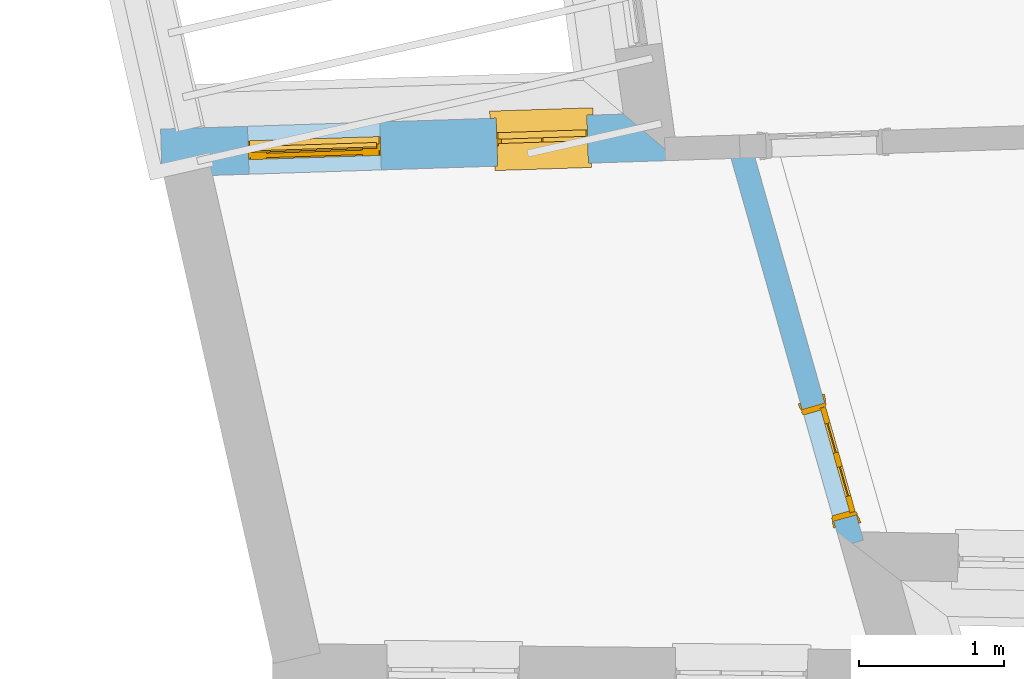
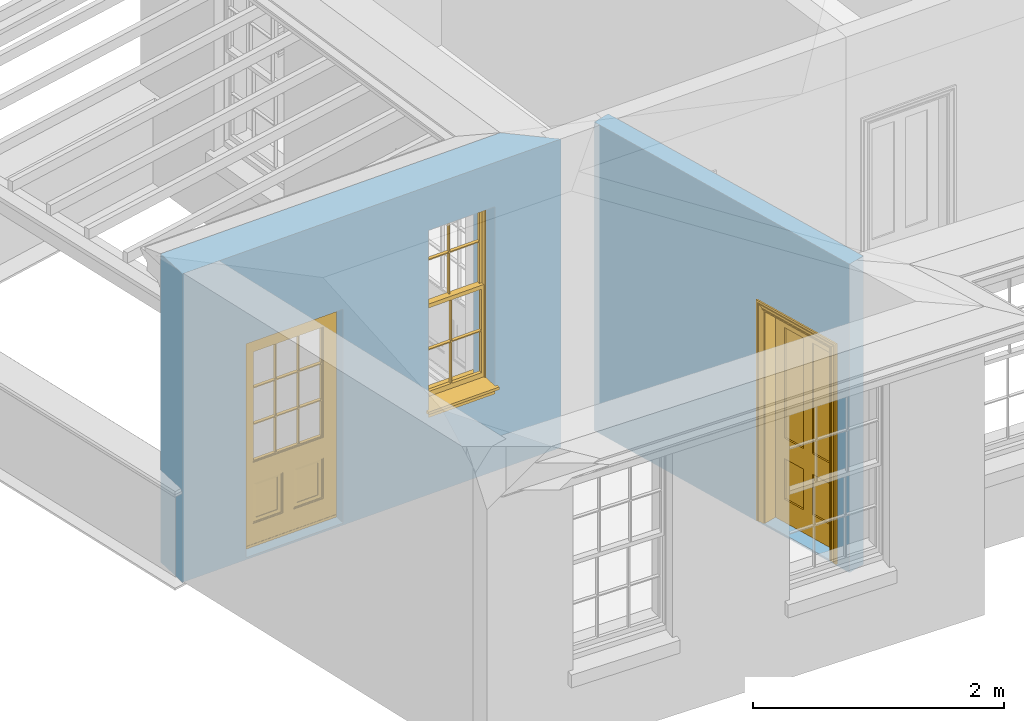
# One storey, part 3 of 11: 2 doors, 1 window, 3 openings, plus 2 elements that do not belong to this part.
"""IFC2X3 building model written with IfcOpenShell, lengths in metres."""

import ifcopenshell
import ifcopenshell.guid

model = None  # the IFC model being written
_history = None  # IfcOwnerHistory: only IFC2X3 demands one
_inside = {}  # id of a spatial element -> (the spatial element, [elements in it])
_under = {}  # id of a project, library or spatial element -> (it, [spatial elements below it])
_declared = {}  # id of a project -> (the project, [libraries it declares])
_typed = {}  # id of a type object -> (the type object, [elements of that type])
_made_of = {}  # id of a material, layer set ... -> (it, [elements and type objects made of it])


def new_model(schema):
    """Start an empty IFC model of exactly this schema.

    Asked for "IFC4X3", IfcOpenShell would pick the latest addendum, in which some entities
    have other attributes; the version numbers below select the first issue.
    IFC2X3 requires an IfcOwnerHistory on every rooted entity: one is made here for all.
    """
    global model, _history
    if schema == "IFC4X3":
        model = ifcopenshell.file(schema_version=(4, 3, 0, 0))
    else:
        model = ifcopenshell.file(schema=schema)
    _inside.clear()
    _under.clear()
    _declared.clear()
    _typed.clear()
    _made_of.clear()
    _history = None
    if model.schema == "IFC2X3":
        org = make("IfcOrganization", Name="unknown")
        user = make(
            "IfcPersonAndOrganization",
            ThePerson=make("IfcPerson", FamilyName="unknown"),
            TheOrganization=org,
        )
        app = make(
            "IfcApplication",
            ApplicationDeveloper=org,
            Version="unknown",
            ApplicationFullName="unknown",
            ApplicationIdentifier="unknown",
        )
        _history = make(
            "IfcOwnerHistory",
            OwningUser=user,
            OwningApplication=app,
            ChangeAction="ADDED",
            CreationDate=0,
        )
    return model


def make(cls, **values):
    """One entity of the class cls with the attributes given. An attribute that is None is left unset."""
    return model.create_entity(
        cls, **{name: value for name, value in values.items() if value is not None}
    )


def rooted(cls, **values):
    """An entity with a GlobalId (a new one), such as an element, a storey or a relation."""
    return make(cls, GlobalId=ifcopenshell.guid.new(), OwnerHistory=_history, **values)


def si_unit(unit_type, name, prefix=None):
    """IfcSIUnit, for example si_unit("LENGTHUNIT", "METRE", prefix="MILLI")."""
    return make("IfcSIUnit", UnitType=unit_type, Prefix=prefix, Name=name)


def assignment(units):
    """IfcUnitAssignment: the units of a project."""
    return None if units is None else make("IfcUnitAssignment", Units=units)


def point(xyz):
    """IfcCartesianPoint."""
    return None if xyz is None else make("IfcCartesianPoint", Coordinates=xyz)


def direction(xyz):
    """IfcDirection."""
    return None if xyz is None else make("IfcDirection", DirectionRatios=xyz)


def frame(location, z_axis=None, x_axis=None):
    """IfcAxis2Placement3D, a coordinate frame: its origin and axes. An axis left out is left unset."""
    return make(
        "IfcAxis2Placement3D",
        Location=point(location),
        Axis=direction(z_axis),
        RefDirection=direction(x_axis),
    )


def origin():
    """The frame at (0, 0, 0) with its axes left unset."""
    return frame((0.0, 0.0, 0.0))


def place(relative_to, where):
    """IfcLocalPlacement: puts the frame where relative to a parent placement (None: the world)."""
    return make(
        "IfcLocalPlacement", PlacementRelTo=relative_to, RelativePlacement=where
    )


def context(
    kind, dimensions, precision=None, world=None, true_north=None, identifier=None
):
    """IfcGeometricRepresentationContext, for example the 3D "Model" context."""
    return make(
        "IfcGeometricRepresentationContext",
        ContextIdentifier=identifier,
        ContextType=kind,
        CoordinateSpaceDimension=dimensions,
        Precision=precision,
        WorldCoordinateSystem=world,
        TrueNorth=true_north,
    )


def subcontext(parent, identifier, kind, view, scale=None):
    """IfcGeometricRepresentationSubContext, for example "Body" below "Model"."""
    return make(
        "IfcGeometricRepresentationSubContext",
        ContextIdentifier=identifier,
        ContextType=kind,
        ParentContext=parent,
        TargetScale=scale,
        TargetView=view,
    )


def project(units=None, contexts=None):
    """IfcProject with its units and contexts."""
    return rooted(
        "IfcProject",
        Name="project",
        RepresentationContexts=contexts,
        UnitsInContext=assignment(units),
    )


def spatial(cls, under=None, at=None, **own):
    """A site, building, storey or space (cls), placed at a placement, below another one or the project."""
    s = rooted(cls, ObjectPlacement=at, **own)
    if under is not None:
        _under.setdefault(under.id(), (under, []))[1].append(s)
    return s


def polyline(points):
    """IfcPolyline through the points."""
    return make("IfcPolyline", Points=[point(p) for p in points])


def outline(outer, holes=None, kind="AREA"):
    """IfcArbitraryClosedProfileDef: a profile drawn as a closed curve; with holes, ...WithVoids."""
    if holes is None:
        return make("IfcArbitraryClosedProfileDef", ProfileType=kind, OuterCurve=outer)
    return make(
        "IfcArbitraryProfileDefWithVoids",
        ProfileType=kind,
        OuterCurve=outer,
        InnerCurves=holes,
    )


def extrude(swept, where, along, depth):
    """IfcExtrudedAreaSolid: the profile swept, set in the frame where, extruded along a direction by depth."""
    return make(
        "IfcExtrudedAreaSolid",
        SweptArea=swept,
        Position=where,
        ExtrudedDirection=direction(along),
        Depth=depth,
    )


def faces_of(points, faces, orient=None, outer=None):
    """IfcFace entities. A face is a list of loops; a loop is a list of indices into points, from 0.

    orient and outer hold one flag for each loop. By default every Orientation is true, the
    first loop of a face is its IfcFaceOuterBound and the others are IfcFaceBound.
    """
    made = []
    for i, loops in enumerate(faces):
        bounds = []
        for j, loop in enumerate(loops):
            is_outer = j == 0 if outer is None else outer[i][j]
            bounds.append(
                make(
                    "IfcFaceOuterBound" if is_outer else "IfcFaceBound",
                    Bound=make("IfcPolyLoop", Polygon=[points[k] for k in loop]),
                    Orientation=True if orient is None else orient[i][j],
                )
            )
        made.append(make("IfcFace", Bounds=bounds))
    return made


def faceted_brep(points, faces, orient=None, outer=None, voids=None):
    """IfcFacetedBrep: a solid bounded by flat faces; with voids (closed shells), ...WithVoids."""
    shared = [point(p) for p in points]
    hull = make("IfcClosedShell", CfsFaces=faces_of(shared, faces, orient, outer))
    if voids is None:
        return make("IfcFacetedBrep", Outer=hull)
    return make(
        "IfcFacetedBrepWithVoids",
        Outer=hull,
        Voids=[
            make(cls, CfsFaces=faces_of(shared, fs, o, b)) for cls, fs, o, b in voids
        ],
    )


def shape(context_of_items, identifier, shape_type, items):
    """IfcShapeRepresentation: the items that make up one representation, for example the "Body"."""
    return make(
        "IfcShapeRepresentation",
        ContextOfItems=context_of_items,
        RepresentationIdentifier=identifier,
        RepresentationType=shape_type,
        Items=items,
    )


def material(Name=None, Category=None):
    """IfcMaterial."""
    return make("IfcMaterial", Name=Name, Category=Category)


def layer(
    of_material, thickness, ventilated=None, Name=None, Category=None, Priority=None
):
    """IfcMaterialLayer: one layer of a wall or slab, of a material (None: an air gap)."""
    return make(
        "IfcMaterialLayer",
        Material=of_material,
        LayerThickness=thickness,
        IsVentilated=ventilated,
        Name=Name,
        Category=Category,
        Priority=Priority,
    )


def layer_set(layers, Name=None):
    """IfcMaterialLayerSet."""
    return make("IfcMaterialLayerSet", MaterialLayers=layers, LayerSetName=Name)


def layer_usage(for_layer_set, set_direction, sense, offset, extent=None):
    """IfcMaterialLayerSetUsage: how a layer set lies in its element."""
    return make(
        "IfcMaterialLayerSetUsage",
        ForLayerSet=for_layer_set,
        LayerSetDirection=set_direction,
        DirectionSense=sense,
        OffsetFromReferenceLine=offset,
        ReferenceExtent=extent,
    )


def made_of(thing, what):
    """Note that an element or type object is made of a material, layer set ...; save() writes the relation."""
    if what is not None:
        _made_of.setdefault(what.id(), (what, []))[1].append(thing)
    return thing


def element(
    cls,
    number,
    at=None,
    inside=None,
    cuts=None,
    type_object=None,
    material=None,
    context=None,
    identifier="Body",
    shape_type=None,
    held_by="IfcProductDefinitionShape",
    body=None,
    shapes=None,
    **own,
):
    """One element of the class cls, such as IfcWall. Its Tag is "e" and its number.

    at: its placement. inside: the storey or other place that contains it. cuts: it is an
    opening in that element (IfcRelVoidsElement). A single representation is given by context,
    identifier, shape_type and body (its items); several are given by shapes. held_by: the class
    of the entity that holds the representations. save() writes the other relations.
    """
    e = rooted(cls, Tag="e%d" % number, ObjectPlacement=at, **own)
    if body is not None:
        shapes = [shape(context, identifier, shape_type, body)]
    if shapes is not None:
        e.Representation = make(held_by, Representations=shapes)
    if inside is not None:
        _inside.setdefault(inside.id(), (inside, []))[1].append(e)
    if cuts is not None:
        rooted(
            "IfcRelVoidsElement", RelatingBuildingElement=cuts, RelatedOpeningElement=e
        )
    if type_object is not None:
        _typed.setdefault(type_object.id(), (type_object, []))[1].append(e)
    return made_of(e, material)


def fill(opening, filler):
    """IfcRelFillsElement: the door or window that sits in an opening."""
    return rooted(
        "IfcRelFillsElement",
        RelatingOpeningElement=opening,
        RelatedBuildingElement=filler,
    )


def aggregate(whole, parts):
    """IfcRelAggregates: a whole, such as a stair, and the parts it consists of."""
    return rooted("IfcRelAggregates", RelatingObject=whole, RelatedObjects=parts)


def save(model, path):
    """Write the relations noted so far, then the file.

    IfcRelAggregates (storeys below a building ...), IfcRelContainedInSpatialStructure (elements
    in a storey), IfcRelDefinesByType, IfcRelAssociatesMaterial and IfcRelDeclares: one each for
    every whole, place, type object, material and project.
    """
    for whole, parts in _under.values():
        aggregate(whole, parts)
    for where, things in _inside.values():
        rooted(
            "IfcRelContainedInSpatialStructure",
            RelatedElements=things,
            RelatingStructure=where,
        )
    for kind, things in _typed.values():
        rooted("IfcRelDefinesByType", RelatedObjects=things, RelatingType=kind)
    for what, things in _made_of.values():
        rooted("IfcRelAssociatesMaterial", RelatedObjects=things, RelatingMaterial=what)
    for by, libraries in _declared.values():
        rooted("IfcRelDeclares", RelatingContext=by, RelatedDefinitions=libraries)
    model.write(path)


model = new_model("IFC2X3")

# Units and contexts
model_context = context("Model", 3, world=origin())
body_context = subcontext(model_context, "Body", "Model", "MODEL_VIEW")
ifc_project = project(units=[si_unit("PLANEANGLEUNIT", "RADIAN"), si_unit("MASSUNIT", "GRAM", prefix="KILO"), si_unit("FORCEUNIT", "NEWTON", prefix="KILO"), si_unit("LENGTHUNIT", "METRE")], contexts=[model_context])

# Site, building, storey
site_placement = place(None, origin())
site = spatial("IfcSite", under=ifc_project, at=site_placement, CompositionType="ELEMENT")
building_placement = place(None, origin())
building = spatial("IfcBuilding", under=site, at=building_placement, Name="Building plot-10", CompositionType="ELEMENT")
storey_placement = place(None, frame((0.0, 0.0, 4.6)))
storey = spatial("IfcBuildingStorey", under=building, at=storey_placement, Name="Floor 1", CompositionType="ELEMENT", Elevation=4.6)

# Wall, openings, window, door
ifc_material_1 = material(Name="Masonry")
ifc_layer_1 = layer(ifc_material_1, 0.33, ventilated=False)
ifc_layer_set_1 = layer_set([ifc_layer_1], Name="My Wall")
ifc_layer_usage_1 = layer_usage(ifc_layer_set_1, "AXIS2", "NEGATIVE", 0.08)
wall_1_placement = place(storey_placement, origin())
wall_1 = element("IfcWallStandardCase", 1, at=wall_1_placement, inside=storey, material=ifc_layer_usage_1, Name="exterior", context=body_context, shape_type="SweptSolid", body=[
    extrude(outline(polyline([(44.9907273404709, 19.9050530553829), (44.613794117192, 20.222948147817), (41.4317582674974, 20.1192816168719), (41.4425035313938, 19.7894566037152), (44.9907273404709, 19.9050530553829)])), origin(), (0.0, 0.0, 1.0), 3.0),
])
opening_1_placement = place(storey_placement, frame((0.0, 0.0, 0.75)))
opening_1 = element("IfcOpeningElement", 2, at=opening_1_placement, cuts=wall_1, Name="Opening", ObjectType="Opening", context=body_context, shape_type="SweptSolid", body=[
    extrude(outline(polyline([(44.3630246910205, 20.2147784106719), (43.7383561054965, 20.1944275320802), (43.7491013693929, 19.8646025189235), (44.3737699549169, 19.8849533975153), (44.3630246910205, 20.2147784106719)])), origin(), (0.0, 0.0, 1.0), 1.82),
])
opening_2_placement = place(storey_placement, frame((0.0, 0.0, 0.0199999999999996)))
opening_2 = element("IfcOpeningElement", 3, at=opening_2_placement, cuts=wall_1, Name="Opening", ObjectType="Opening", context=body_context, shape_type="SweptSolid", body=[
    extrude(outline(polyline([(42.9387803160258, 20.1683784074828), (42.0292628555029, 20.1387475282532), (42.0400081193993, 19.8089225150966), (42.9495255799222, 19.8385533943261), (42.9387803160258, 20.1683784074828)])), origin(), (0.0, 0.0, 1.0), 2.08),
])
window_placement = place(storey_placement, frame((44.3711650424572, 19.9649109764623, 0.75), z_axis=(0.0, 0.0, 1.0), x_axis=(-0.624668585523992, -0.0203508785917279, 0.0)))
window = element("IfcWindow", 4, at=window_placement, inside=storey, Name="bedroom outside window", OverallHeight=1.82, OverallWidth=0.625, context=body_context, shape_type="Brep", held_by="IfcProductRepresentation", body=[
    faceted_brep([(0.033125, -0.105, 0.975209), (0.01, -0.105, 0.975209), (0.033125, -0.105, 1.376042), (0.591875, -0.105, 0.975209), (0.591875, -0.105, 1.376042), (0.615, -0.105, 0.975209), (0.591875, -0.105, 1.386042), (0.591875, -0.105, 1.786875), (0.615, -0.105, 1.81), (0.033125, -0.105, 1.786875), (0.033125, -0.105, 1.386042), (0.01, -0.105, 1.81), (0.591875, -0.135, 1.376042), (0.591875, -0.135, 0.975209), (0.615, -0.135, 0.937083), (0.033125, -0.135, 1.786875), (0.01, -0.135, 1.81), (0.033125, -0.135, 1.386042), (0.01, -0.135, 0.937083), (0.033125, -0.135, 0.975209), (0.033125, -0.135, 1.376042), (0.591875, -0.135, 1.786875), (0.591875, -0.135, 1.386042), (0.615, -0.135, 1.81), (0.033125, -0.105, 0.937083), (0.01, -0.105, 0.937083), (0.033125, -0.105, 0.53625), (0.591875, -0.105, 0.937083), (0.591875, -0.105, 0.53625), (0.615, -0.105, 0.937083), (0.591875, -0.105, 0.52625), (0.591875, -0.105, 0.125417), (0.615, -0.105, 0.077167), (0.033125, -0.105, 0.125417), (0.033125, -0.105, 0.52625), (0.01, -0.105, 0.077167), (-0.0425, -0.25, 0.01), (-0.0425, -0.3, 0.001667), (0.0, -0.25, 0.01), (0.6675, -0.25, 0.01), (0.625, -0.25, 0.01), (0.6675, -0.3, 0.001667), (-0.02, 0.08, 0.077167), (0.0, 0.08, 0.077167), (-0.02, 0.11, 0.077167), (0.0, -0.06, 0.077167), (0.01, -0.06, 0.077167), (0.625, -0.06, 0.077167), (0.625, 0.08, 0.077167), (0.615, -0.06, 0.077167), (0.645, 0.08, 0.077167), (0.645, 0.11, 0.077167), (0.01, -0.075, 0.975209), (0.615, -0.075, 0.975209), (0.591875, -0.075, 0.125417), (0.591875, -0.075, 0.52625), (0.615, -0.075, 0.077167), (0.591875, -0.075, 0.53625), (0.591875, -0.075, 0.937083), (0.033125, -0.075, 0.125417), (0.01, -0.075, 0.077167), (0.033125, -0.075, 0.52625), (0.033125, -0.075, 0.937083), (0.033125, -0.075, 0.53625), (-0.02, 0.08, 0.052167), (-0.02, 0.11, 0.052167), (0.645, 0.11, 0.052167), (0.645, 0.08, 0.052167), (0.625, 0.08, 0.052167), (0.0, 0.08, 0.052167), (0.625, -0.15, 0.026667), (0.0, -0.15, 0.026667), (-0.0425, -0.3, -0.123333), (0.6675, -0.3, -0.123333), (-0.0425, -0.25, -0.123333), (0.6675, -0.25, -0.123333), (0.01, -0.06, 1.81), (0.615, -0.06, 1.81), (0.0, -0.06, 1.82), (0.625, -0.06, 1.82), (0.01, -0.15, 0.077167), (0.615, -0.15, 0.077167), (0.3175, -0.075, 0.53625), (0.3175, -0.105, 0.53625), (0.3175, -0.075, 0.52625), (0.3175, -0.075, 0.125417), (0.3075, -0.075, 0.125417), (0.3075, -0.075, 0.52625), (0.3075, -0.075, 0.53625), (0.3175, -0.075, 0.937083), (0.3075, -0.075, 0.937083), (0.3075, -0.105, 0.52625), (0.3075, -0.105, 0.125417), (0.3175, -0.105, 0.125417), (0.3175, -0.105, 0.52625), (0.3075, -0.105, 0.53625), (0.3075, -0.105, 0.937083), (0.3175, -0.105, 0.937083), (0.3075, -0.135, 1.386042), (0.3075, -0.135, 1.376042), (0.3175, -0.135, 1.376042), (0.3075, -0.135, 0.975209), (0.3175, -0.135, 0.975209), (0.3175, -0.135, 1.786875), (0.3075, -0.135, 1.786875), (0.3175, -0.135, 1.386042), (0.3175, -0.105, 1.386042), (0.3175, -0.105, 1.376042), (0.3075, -0.105, 1.386042), (0.3075, -0.105, 1.786875), (0.3175, -0.105, 1.786875), (0.3075, -0.105, 1.376042), (0.3175, -0.105, 0.975209), (0.3075, -0.105, 0.975209), (0.625, -0.15, 1.82), (0.615, -0.15, 1.81), (0.01, -0.15, 1.81), (0.0, -0.15, 1.82), (0.625, -0.25, 0.0), (0.0, -0.25, 0.0), (0.625, 0.08, 0.0), (0.0, 0.08, 0.0)], [[[0, 1, 2]], [[3, 4, 5]], [[6, 7, 8]], [[9, 10, 11]], [[12, 13, 14]], [[15, 16, 17]], [[18, 19, 20]], [[21, 22, 23]], [[24, 25, 26]], [[27, 28, 29]], [[30, 31, 32]], [[33, 34, 35]], [[14, 27, 29]], [[25, 24, 18]], [[36, 37, 38]], [[39, 40, 41]], [[42, 43, 44]], [[45, 46, 43]], [[47, 48, 49]], [[50, 51, 48]], [[1, 0, 52]], [[5, 53, 3]], [[54, 55, 56]], [[57, 58, 53]], [[59, 60, 61]], [[62, 63, 52]], [[48, 43, 46, 49]], [[51, 44, 43, 48]], [[64, 42, 44, 65]], [[65, 44, 51, 66]], [[66, 51, 50, 67]], [[65, 66, 68, 69]], [[60, 56, 49, 46]], [[70, 71, 38, 40]], [[37, 41, 40, 38]], [[37, 72, 73, 41]], [[74, 75, 73, 72]], [[8, 11, 76, 77]], [[76, 78, 79, 77]], [[32, 35, 80, 81]], [[81, 80, 71, 70]], [[28, 57, 82, 83]], [[84, 85, 86, 87]], [[88, 87, 61, 63]], [[89, 82, 88, 90]], [[84, 82, 57, 55]], [[91, 87, 86, 92]], [[34, 61, 87, 91]], [[93, 85, 84, 94]], [[95, 88, 63, 26]], [[96, 90, 88, 95]], [[83, 82, 89, 97]], [[94, 84, 55, 30]], [[94, 30, 28, 83]], [[94, 91, 92, 93]], [[95, 26, 34, 91]], [[97, 96, 95, 83]], [[98, 17, 20, 99]], [[100, 99, 101, 102]], [[103, 104, 98, 105]], [[100, 12, 22, 105]], [[106, 6, 4, 107]], [[106, 108, 109, 110]], [[111, 2, 10, 108]], [[112, 113, 111, 107]], [[99, 111, 113, 101]], [[20, 2, 111, 99]], [[102, 112, 107, 100]], [[98, 108, 10, 17]], [[104, 109, 108, 98]], [[105, 106, 110, 103]], [[22, 6, 106, 105]], [[100, 107, 4, 12]], [[82, 84, 87, 88]], [[83, 95, 91, 94]], [[99, 100, 105, 98]], [[107, 111, 108, 106]], [[92, 86, 59, 33]], [[15, 9, 109, 104]], [[103, 110, 7, 21]], [[31, 54, 85, 93]], [[36, 74, 72, 37]], [[39, 41, 73, 75]], [[18, 14, 102, 101]], [[23, 16, 104, 103]], [[85, 56, 60, 86]], [[52, 53, 89, 90]], [[53, 52, 113, 112]], [[11, 8, 110, 109]], [[14, 18, 96, 97]], [[2, 1, 11, 10]], [[8, 5, 4, 6]], [[57, 53, 56, 55]], [[60, 52, 63, 61]], [[26, 25, 35, 34]], [[32, 29, 28, 30]], [[14, 23, 22, 12]], [[18, 20, 17, 16]], [[19, 0, 2, 20]], [[17, 10, 9, 15]], [[12, 4, 3, 13]], [[21, 7, 6, 22]], [[27, 58, 57, 28]], [[30, 55, 54, 31]], [[33, 59, 61, 34]], [[26, 63, 62, 24]], [[5, 8, 77, 53]], [[76, 11, 1, 52]], [[46, 45, 78, 76]], [[49, 77, 79, 47]], [[70, 114, 115, 81]], [[71, 80, 116, 117]], [[19, 101, 113, 0]], [[102, 13, 3, 112]], [[90, 96, 24, 62]], [[29, 32, 81, 14]], [[80, 35, 25, 18]], [[60, 46, 76, 52]], [[77, 49, 56, 53]], [[23, 14, 81, 115]], [[16, 116, 80, 18]], [[92, 33, 35]], [[32, 31, 93]], [[32, 93, 92, 35]], [[14, 13, 102]], [[101, 19, 18]], [[103, 21, 23]], [[16, 15, 104]], [[109, 9, 11]], [[8, 7, 110]], [[23, 115, 116, 16]], [[114, 117, 116, 115]], [[90, 62, 52]], [[58, 89, 53]], [[27, 97, 89, 58]], [[85, 54, 56]], [[60, 59, 86]], [[97, 27, 14]], [[18, 24, 96]], [[52, 0, 113]], [[112, 3, 53]], [[79, 78, 117, 114]], [[78, 45, 71, 117]], [[114, 70, 47, 79]], [[118, 75, 74, 119]], [[68, 66, 67]], [[48, 68, 67, 50]], [[69, 64, 65]], [[42, 64, 69, 43]], [[69, 68, 120, 121]], [[70, 68, 48, 47]], [[118, 120, 68, 70]], [[43, 69, 71, 45]], [[69, 121, 119, 71]], [[120, 118, 119, 121]], [[38, 119, 74, 36]], [[71, 119, 38]], [[39, 75, 118, 40]], [[40, 118, 70]]]),
])
fill(opening_1, window)
door_1_placement = place(storey_placement, frame((42.9469206674625, 19.9185109732732, 0.0199999999999996), z_axis=(0.0, 0.0, 1.0), x_axis=(-0.909517460522935, -0.0296308792295576, 0.0)))
door_1 = element("IfcDoor", 5, at=door_1_placement, inside=storey, Name="bedroom outside door", OverallHeight=2.08, OverallWidth=0.91, context=body_context, shape_type="Brep", held_by="IfcProductRepresentation", body=[
    faceted_brep([(0.545, -0.055, 0.265), (0.745, -0.055, 0.265), (0.745, -0.05, 0.265), (0.545, -0.05, 0.265), (0.745, -0.05, 0.58), (0.545, -0.05, 0.58), (0.545, -0.055, 0.58), (0.515, -0.06, 0.235), (0.775, -0.06, 0.235), (0.745, -0.055, 0.58), (0.515, -0.06, 0.61), (0.515, -0.065, 0.235), (0.775, -0.065, 0.235), (0.775, -0.06, 0.61), (0.515, -0.065, 0.61), (0.785, -0.065, 0.225), (0.505, -0.065, 0.225), (0.775, -0.065, 0.61), (0.505, -0.065, 0.62), (0.785, -0.065, 0.62), (0.505, -0.07, 0.225), (0.785, -0.07, 0.225), (0.505, -0.07, 0.62), (0.785, -0.07, 0.62), (0.883, -0.07, 0.075), (0.898, -0.07, 0.075), (0.405, -0.07, 0.62), (0.405, -0.07, 0.225), (0.027, -0.07, 0.075), (0.785, -0.07, 0.82), (0.125, -0.07, 0.82), (0.405, -0.065, 0.62), (0.405, -0.065, 0.225), (0.898, -0.07, 2.068), (0.027, -0.08, 0.075), (0.883, -0.08, 0.075), (0.125, -0.07, 0.225), (0.012, -0.07, 0.075), (0.785, -0.06, 0.82), (0.125, -0.06, 0.82), (0.125, -0.07, 0.62), (0.125, -0.065, 0.62), (0.395, -0.065, 0.61), (0.395, -0.065, 0.235), (0.125, -0.065, 0.225), (0.785, -0.07, 1.895), (0.027, -0.11, 0.045), (0.883, -0.11, 0.045), (0.558333, -0.06, 0.83), (0.351667, -0.06, 0.83), (0.125, -0.07, 1.895), (0.125, -0.06, 1.895), (0.785, -0.06, 1.895), (0.012, -0.07, 2.068), (0.135, -0.065, 0.61), (0.395, -0.06, 0.61), (0.395, -0.06, 0.235), (0.135, -0.065, 0.235), (0.027, -0.11, 0.027), (0.883, -0.11, 0.027), (0.568333, -0.06, 0.83), (0.558333, -0.03, 0.83), (0.351667, -0.03, 0.83), (0.341667, -0.06, 0.83), (0.135, -0.06, 1.185), (0.135, -0.06, 1.53), (0.775, -0.06, 1.53), (0.775, -0.06, 1.185), (0.135, -0.06, 0.61), (0.365, -0.055, 0.58), (0.365, -0.055, 0.265), (0.135, -0.06, 0.235), (0.568333, -0.06, 1.175), (0.558333, -0.06, 1.175), (0.775, -0.06, 0.83), (0.558333, -0.03, 1.175), (0.785, -0.03, 0.82), (0.125, -0.03, 0.82), (0.351667, -0.03, 1.175), (0.351667, -0.06, 1.175), (0.341667, -0.06, 1.175), (0.135, -0.06, 0.83), (0.135, -0.06, 1.175), (0.135, -0.03, 1.185), (0.135, -0.03, 1.53), (0.135, -0.06, 1.54), (0.351667, -0.06, 1.885), (0.558333, -0.06, 1.885), (0.775, -0.03, 1.53), (0.775, -0.03, 1.185), (0.775, -0.06, 1.175), (0.775, -0.06, 1.54), (0.165, -0.055, 0.58), (0.365, -0.05, 0.58), (0.365, -0.05, 0.265), (0.165, -0.055, 0.265), (0.568333, -0.03, 0.83), (0.568333, -0.03, 1.175), (0.568333, -0.06, 1.185), (0.558333, -0.06, 1.185), (0.775, -0.03, 0.83), (0.785, -0.02, 0.82), (0.125, -0.02, 0.82), (0.341667, -0.03, 0.83), (0.341667, -0.03, 1.175), (0.351667, -0.06, 1.185), (0.341667, -0.06, 1.185), (0.135, -0.03, 0.83), (0.341667, -0.03, 1.185), (0.125, -0.03, 1.895), (0.341667, -0.03, 1.53), (0.341667, -0.06, 1.53), (0.135, -0.06, 1.885), (0.341667, -0.06, 1.54), (0.341667, -0.06, 1.885), (0.558333, -0.03, 1.885), (0.351667, -0.03, 1.885), (0.568333, -0.06, 1.885), (0.785, -0.03, 1.895), (0.568333, -0.03, 1.185), (0.568333, -0.06, 1.53), (0.568333, -0.03, 1.53), (0.568333, -0.06, 1.54), (0.775, -0.06, 1.885), (0.165, -0.05, 0.58), (0.165, -0.05, 0.265), (0.775, -0.03, 1.175), (0.558333, -0.06, 1.53), (0.351667, -0.03, 1.185), (0.558333, -0.03, 1.185), (0.505, -0.02, 0.62), (0.405, -0.02, 0.62), (0.125, -0.02, 1.895), (0.785, -0.02, 1.895), (0.351667, -0.06, 1.53), (0.135, -0.03, 1.175), (0.135, -0.03, 1.54), (0.341667, -0.03, 1.54), (0.135, -0.03, 1.885), (0.351667, -0.06, 1.54), (0.558333, -0.03, 1.54), (0.558333, -0.06, 1.54), (0.351667, -0.03, 1.54), (0.775, -0.03, 1.54), (0.568333, -0.03, 1.54), (0.775, -0.03, 1.885), (0.558333, -0.03, 1.53), (0.405, -0.02, 0.225), (0.505, -0.02, 0.225), (0.125, -0.02, 0.62), (0.785, -0.02, 0.62), (0.012, -0.02, 2.068), (0.898, -0.02, 2.068), (0.351667, -0.03, 1.53), (0.341667, -0.03, 1.885), (0.568333, -0.03, 1.885), (0.405, -0.025, 0.225), (0.405, -0.025, 0.62), (0.505, -0.025, 0.62), (0.505, -0.025, 0.225), (0.898, -0.02, 0.027), (0.012, -0.02, 0.027), (0.125, -0.025, 0.62), (0.785, -0.025, 0.62), (0.395, -0.025, 0.235), (0.395, -0.025, 0.61), (0.125, -0.02, 0.225), (0.125, -0.025, 0.225), (0.515, -0.025, 0.61), (0.515, -0.025, 0.235), (0.785, -0.02, 0.225), (0.785, -0.025, 0.225), (0.135, -0.025, 0.61), (0.775, -0.025, 0.61), (0.135, -0.025, 0.235), (0.395, -0.03, 0.235), (0.395, -0.03, 0.61), (0.515, -0.03, 0.61), (0.515, -0.03, 0.235), (0.775, -0.025, 0.235), (0.135, -0.03, 0.61), (0.775, -0.03, 0.61), (0.135, -0.03, 0.235), (0.365, -0.035, 0.265), (0.365, -0.035, 0.58), (0.545, -0.035, 0.58), (0.545, -0.035, 0.265), (0.775, -0.03, 0.235), (0.165, -0.035, 0.58), (0.745, -0.035, 0.58), (0.165, -0.035, 0.265), (0.365, -0.04, 0.58), (0.365, -0.04, 0.265), (0.545, -0.04, 0.58), (0.545, -0.04, 0.265), (0.745, -0.035, 0.265), (0.165, -0.04, 0.58), (0.745, -0.04, 0.58), (0.165, -0.04, 0.265), (0.745, -0.04, 0.265), (0.885, -0.072, 0.025), (0.025, -0.072, 0.025), (0.025, -0.1, 0.025), (0.885, -0.1, 0.025), (0.9, -0.02, 0.025), (0.01, -0.02, 0.025), (0.9, -0.072, 0.025), (0.91, -0.02, 0.0), (0.0, -0.02, 0.0), (0.01, -0.072, 0.025), (0.9, -0.072, 2.07), (0.9, -0.02, 2.07), (0.885, -0.072, 2.055), (0.91, -0.02, 2.08), (0.01, -0.02, 2.07), (0.0, -0.02, 2.08), (0.01, -0.072, 2.07), (0.025, -0.072, 2.055), (0.0, -0.15, 2.08), (0.91, -0.15, 2.08), (0.01, -0.15, 2.07), (0.9, -0.15, 2.07), (0.01, -0.1, 2.07), (0.9, -0.1, 2.07), (0.0, -0.15, 0.0), (0.91, -0.15, 0.0), (0.01, -0.15, 0.025), (0.9, -0.15, 0.025), (0.01, -0.1, 0.025), (0.025, -0.1, 2.055), (0.9, -0.1, 0.025), (0.885, -0.1, 2.055), (0.898, -0.07, 0.027), (0.012, -0.07, 0.027), (0.883, -0.07, 0.027), (0.027, -0.07, 0.027)], [[[0, 1, 2, 3]], [[2, 4, 5, 3]], [[0, 3, 5, 6]], [[1, 0, 7, 8]], [[9, 4, 2, 1]], [[9, 6, 5, 4]], [[0, 6, 10, 7]], [[8, 7, 11, 12]], [[8, 13, 9, 1]], [[13, 10, 6, 9]], [[7, 10, 14, 11]], [[15, 12, 11, 16]], [[12, 17, 13, 8]], [[17, 14, 10, 13]], [[18, 16, 11, 14]], [[15, 19, 17, 12]], [[15, 16, 20, 21]], [[14, 17, 19, 18]], [[16, 18, 22, 20]], [[21, 23, 19, 15]], [[24, 25, 21, 20]], [[23, 22, 18, 19]], [[20, 22, 26, 27]], [[23, 21, 25]], [[28, 24, 20, 27]], [[22, 23, 29]], [[29, 30, 26, 22]], [[27, 26, 31, 32]], [[23, 25, 33, 29]], [[34, 35, 24, 28]], [[28, 27, 36, 37]], [[38, 39, 30, 29]], [[26, 30, 40]], [[26, 40, 41, 31]], [[42, 43, 32, 31]], [[32, 44, 36, 27]], [[33, 45, 29]], [[46, 47, 35, 34]], [[36, 40, 37]], [[39, 38, 48, 49]], [[50, 30, 39, 51]], [[29, 45, 52, 38]], [[53, 37, 40, 30]], [[44, 41, 40, 36]], [[31, 41, 54, 42]], [[43, 42, 55, 56]], [[57, 44, 32, 43]], [[50, 45, 33, 53]], [[47, 46, 58, 59]], [[60, 48, 38]], [[49, 48, 61, 62]], [[49, 63, 39]], [[50, 53, 30]], [[51, 39, 64, 65]], [[45, 50, 51, 52]], [[66, 67, 38, 52]], [[57, 54, 41, 44]], [[42, 54, 68, 55]], [[56, 55, 69, 70]], [[56, 71, 57, 43]], [[60, 72, 73, 48]], [[60, 38, 74]], [[48, 73, 75, 61]], [[76, 77, 62, 61]], [[62, 78, 79, 49]], [[49, 79, 80, 63]], [[63, 81, 39]], [[82, 64, 39]], [[65, 64, 83, 84]], [[85, 51, 65]], [[52, 51, 86, 87]], [[88, 89, 67, 66]], [[90, 38, 67]], [[91, 66, 52]], [[71, 68, 54, 57]], [[55, 68, 92, 69]], [[69, 93, 94, 70]], [[70, 95, 71, 56]], [[96, 97, 72, 60]], [[73, 72, 98, 99]], [[74, 38, 90]], [[100, 96, 60, 74]], [[75, 73, 79, 78]], [[61, 75, 97, 96]], [[101, 102, 77, 76]], [[77, 103, 62]], [[96, 76, 61]], [[103, 104, 78, 62]], [[80, 79, 105, 106]], [[63, 80, 104, 103]], [[81, 63, 103, 107]], [[81, 82, 39]], [[106, 64, 82, 80]], [[106, 108, 83, 64]], [[84, 83, 77, 109]], [[110, 111, 65, 84]], [[112, 51, 85]], [[113, 85, 65, 111]], [[114, 86, 51]], [[115, 87, 86, 116]], [[117, 52, 87]], [[118, 76, 89, 88]], [[119, 98, 67, 89]], [[120, 121, 88, 66]], [[67, 98, 72, 90]], [[91, 122, 120, 66]], [[91, 52, 123]], [[95, 92, 68, 71]], [[69, 92, 124, 93]], [[94, 93, 124, 125]], [[94, 125, 95, 70]], [[72, 97, 126, 90]], [[127, 99, 98, 120]], [[99, 105, 79, 73]], [[74, 90, 126, 100]], [[96, 100, 76]], [[128, 129, 75, 78]], [[97, 75, 129, 119]], [[130, 131, 102, 101]], [[109, 77, 102, 132]], [[133, 101, 76, 118]], [[77, 107, 103]], [[78, 104, 108, 128]], [[111, 106, 105, 134]], [[104, 80, 82, 135]], [[107, 135, 82, 81]], [[110, 108, 106, 111]], [[104, 135, 83, 108]], [[83, 135, 77]], [[136, 84, 109]], [[110, 84, 136, 137]], [[114, 51, 112]], [[85, 136, 138, 112]], [[113, 137, 136, 85]], [[111, 134, 139, 113]], [[86, 114, 113, 139]], [[140, 141, 87, 115]], [[139, 142, 116, 86]], [[109, 118, 115, 116]], [[117, 123, 52]], [[117, 87, 141, 122]], [[126, 89, 76]], [[143, 118, 88]], [[120, 98, 119, 121]], [[119, 89, 126, 97]], [[144, 143, 88, 121]], [[144, 122, 91, 143]], [[127, 120, 122, 141]], [[143, 91, 123, 145]], [[124, 92, 95, 125]], [[146, 129, 99, 127]], [[99, 129, 128, 105]], [[100, 126, 76]], [[121, 119, 129, 146]], [[147, 131, 130, 148]], [[131, 149, 102]], [[130, 101, 150]], [[102, 151, 132]], [[118, 109, 132, 133]], [[101, 133, 152]], [[107, 77, 135]], [[153, 128, 108, 110]], [[134, 105, 128, 153]], [[109, 138, 136]], [[153, 110, 137, 142]], [[154, 114, 112, 138]], [[137, 113, 114, 154]], [[141, 139, 134, 127]], [[141, 140, 142, 139]], [[144, 140, 115, 155]], [[142, 137, 154, 116]], [[155, 115, 118]], [[116, 154, 109]], [[117, 155, 145, 123]], [[122, 144, 155, 117]], [[143, 145, 118]], [[121, 146, 140, 144]], [[146, 127, 134, 153]], [[156, 157, 131, 147]], [[148, 130, 158, 159]], [[148, 160, 161, 147]], [[157, 162, 149, 131]], [[161, 151, 102, 149]], [[101, 152, 160, 150]], [[163, 158, 130, 150]], [[151, 152, 133, 132]], [[154, 138, 109]], [[142, 140, 146, 153]], [[145, 155, 118]], [[157, 156, 164, 165]], [[147, 166, 167, 156]], [[168, 169, 159, 158]], [[170, 148, 159, 171]], [[148, 170, 160]], [[166, 147, 161]], [[172, 162, 157, 165]], [[166, 149, 162, 167]], [[166, 161, 149]], [[150, 160, 170]], [[163, 173, 168, 158]], [[171, 163, 150, 170]], [[174, 164, 156, 167]], [[175, 176, 165, 164]], [[169, 168, 177, 178]], [[171, 159, 169, 179]], [[167, 162, 172, 174]], [[176, 180, 172, 165]], [[179, 173, 163, 171]], [[181, 177, 168, 173]], [[164, 174, 182, 175]], [[183, 184, 176, 175]], [[178, 177, 185, 186]], [[179, 169, 178, 187]], [[174, 172, 180, 182]], [[184, 188, 180, 176]], [[187, 181, 173, 179]], [[189, 185, 177, 181]], [[175, 182, 190, 183]], [[191, 184, 183, 192]], [[185, 193, 194, 186]], [[187, 178, 186, 195]], [[182, 180, 188, 190]], [[191, 196, 188, 184]], [[195, 189, 181, 187]], [[197, 193, 185, 189]], [[183, 190, 198, 192]], [[198, 196, 191, 192]], [[194, 193, 197, 199]], [[195, 186, 194, 199]], [[188, 196, 198, 190]], [[197, 189, 195, 199]], [[200, 201, 202, 203]], [[201, 200, 204, 205]], [[206, 204, 200]], [[204, 207, 208, 205]], [[209, 201, 205]], [[210, 211, 204, 206]], [[206, 200, 212, 210]], [[211, 213, 207, 204]], [[214, 205, 208, 215]], [[216, 217, 201, 209]], [[205, 214, 216, 209]], [[216, 214, 211, 210]], [[210, 212, 217, 216]], [[214, 215, 213, 211]], [[218, 219, 213, 215]], [[219, 218, 220, 221]], [[221, 220, 222, 223]], [[215, 208, 224, 218]], [[225, 224, 208, 207]], [[224, 226, 220, 218]], [[224, 225, 227, 226]], [[219, 225, 207, 213]], [[228, 222, 220, 226]], [[219, 221, 227, 225]], [[226, 227, 203, 202]], [[202, 229, 222, 228]], [[228, 226, 202]], [[227, 221, 223, 230]], [[230, 203, 227]], [[217, 229, 202, 201]], [[231, 223, 222, 229]], [[230, 223, 231, 203]], [[231, 229, 217, 212]], [[212, 200, 203, 231]], [[33, 152, 151, 53]], [[25, 160, 152, 33]], [[161, 37, 53, 151]], [[232, 160, 25]], [[161, 233, 37]], [[160, 232, 234]], [[24, 234, 232, 25]], [[233, 161, 235]], [[37, 233, 235, 28]], [[161, 160, 234, 235]], [[35, 47, 234, 24]], [[28, 235, 46, 34]], [[58, 235, 234, 59]], [[59, 234, 47]], [[58, 46, 235]]]),
])
fill(opening_2, door_1)

# Wall, opening, door
ifc_material_2 = material(Name="Masonry")
ifc_layer_2 = layer(ifc_material_2, 0.16, ventilated=False)
ifc_layer_set_2 = layer_set([ifc_layer_2], Name="My Wall")
ifc_layer_usage_2 = layer_usage(ifc_layer_set_2, "AXIS2", "NEGATIVE", 0.08)
wall_2_placement = place(storey_placement, origin())
wall_2 = element("IfcWallStandardCase", 6, at=wall_2_placement, inside=storey, material=ifc_layer_usage_2, Name="interior", context=body_context, shape_type="SweptSolid", body=[
    extrude(outline(polyline([(45.4907977881731, 20.0206996049078), (45.3368641675435, 19.977059709859), (46.1101009560166, 17.2495751840421), (46.2640345766462, 17.2932150790909), (45.4907977881731, 20.0206996049078)])), origin(), (0.0, 0.0, 1.0), 3.0),
])
opening_3_placement = place(storey_placement, frame((0.0, 0.0, 0.0199999999999996)))
opening_3 = element("IfcOpeningElement", 7, at=opening_3_placement, cuts=wall_2, Name="Opening", ObjectType="Opening", context=body_context, shape_type="SweptSolid", body=[
    extrude(outline(polyline([(45.8428065988432, 18.1924186103984), (46.0610060740868, 17.4227505072504), (46.2149396947164, 17.4663904022992), (45.9967402194728, 18.2360585054471), (45.8428065988432, 18.1924186103984)])), origin(), (0.0, 0.0, 1.0), 2.1),
])
door_2_placement = place(storey_placement, frame((45.919773409158, 18.2142385579228, 0.0199999999999996), z_axis=(0.0, 0.0, 1.0), x_axis=(0.218199475243622, -0.769668103147982, 0.0)))
door_2 = element("IfcDoor", 8, at=door_2_placement, inside=storey, Name="bedroom inside door", OverallHeight=2.1, OverallWidth=0.8, context=body_context, shape_type="Brep", held_by="IfcProductRepresentation", body=[
    faceted_brep([(0.773, 0.08, 1.895), (0.66, 0.08, 1.895), (0.66, 0.08, 2.073), (0.773, 0.08, 2.073), (0.773, 0.08, 0.82), (0.66, 0.08, 0.82), (0.45, 0.08, 1.895), (0.45, 0.08, 2.073), (0.773, 0.08, 0.62), (0.66, 0.08, 0.62), (0.66, 0.065, 0.82), (0.66, 0.065, 1.895), (0.45, 0.065, 1.895), (0.35, 0.08, 1.895), (0.35, 0.08, 2.073), (0.773, 0.08, 0.225), (0.66, 0.08, 0.225), (0.45, 0.08, 0.62), (0.45, 0.08, 0.82), (0.45, 0.065, 0.82), (0.35, 0.08, 0.82), (0.14, 0.08, 2.073), (0.14, 0.08, 1.895), (0.773, 0.08, 0.0), (0.66, 0.08, 0.0), (0.66, 0.065, 0.225), (0.66, 0.065, 0.62), (0.45, 0.065, 0.62), (0.35, 0.08, 0.62), (0.35, 0.065, 0.82), (0.35, 0.065, 1.895), (0.14, 0.065, 1.895), (0.027, 0.08, 2.073), (0.027, 0.08, 1.895), (0.773, 0.042, 0.0), (0.66, 0.042, 0.0), (0.45, 0.08, 0.0), (0.45, 0.08, 0.225), (0.45, 0.065, 0.225), (0.35, 0.08, 0.225), (0.14, 0.08, 0.82), (0.14, 0.08, 0.62), (0.14, 0.065, 0.82), (0.027, 0.08, 0.82), (0.773, 0.042, 0.225), (0.66, 0.042, 0.225), (0.45, 0.042, 0.0), (0.35, 0.08, 0.0), (0.35, 0.065, 0.225), (0.35, 0.065, 0.62), (0.14, 0.065, 0.62), (0.027, 0.08, 0.62), (0.773, 0.042, 0.62), (0.66, 0.042, 0.62), (0.45, 0.042, 0.225), (0.35, 0.042, 0.0), (0.14, 0.08, 0.225), (0.14, 0.08, 0.0), (0.14, 0.065, 0.225), (0.027, 0.08, 0.225), (0.773, 0.042, 0.82), (0.66, 0.042, 0.82), (0.66, 0.057, 0.62), (0.66, 0.057, 0.225), (0.45, 0.057, 0.225), (0.35, 0.042, 0.225), (0.14, 0.042, 0.0), (0.027, 0.08, 0.0), (0.773, 0.042, 1.895), (0.66, 0.042, 1.895), (0.45, 0.042, 0.62), (0.45, 0.042, 0.82), (0.45, 0.057, 0.62), (0.35, 0.042, 0.62), (0.14, 0.042, 0.225), (0.027, 0.042, 0.0), (0.773, 0.042, 2.073), (0.66, 0.042, 2.073), (0.66, 0.057, 1.895), (0.66, 0.057, 0.82), (0.45, 0.057, 0.82), (0.35, 0.042, 0.82), (0.35, 0.057, 0.62), (0.35, 0.057, 0.225), (0.14, 0.057, 0.225), (0.027, 0.042, 0.225), (0.45, 0.042, 1.895), (0.45, 0.042, 2.073), (0.45, 0.057, 1.895), (0.35, 0.042, 1.895), (0.14, 0.042, 0.82), (0.14, 0.042, 0.62), (0.14, 0.057, 0.62), (0.027, 0.042, 0.62), (0.35, 0.042, 2.073), (0.35, 0.057, 1.895), (0.35, 0.057, 0.82), (0.14, 0.057, 0.82), (0.027, 0.042, 0.82), (0.14, 0.042, 2.073), (0.14, 0.042, 1.895), (0.14, 0.057, 1.895), (0.027, 0.042, 1.895), (0.027, 0.042, 2.073), (0.02, 0.085, 0.0), (0.005, 0.09, 0.0), (0.005, 0.09, 2.095), (0.02, 0.085, 2.08), (0.02, 0.08, 0.0), (0.0, 0.085, 0.0), (0.0, 0.085, 2.1), (0.795, 0.09, 2.095), (0.78, 0.085, 2.08), (0.02, 0.08, 2.08), (0.0, 0.08, 0.0), (-0.032, 0.095, 0.0), (-0.032, 0.095, 2.132), (0.8, 0.085, 2.1), (0.795, 0.09, 0.0), (0.78, 0.085, 0.0), (0.78, 0.08, 2.08), (0.04, 0.04, 0.0), (0.025, 0.04, 0.0), (0.025, 0.04, 2.075), (0.04, 0.04, 2.06), (-0.04, 0.09, 0.0), (-0.04, 0.09, 2.14), (0.832, 0.095, 2.132), (0.8, 0.085, 0.0), (0.78, 0.08, 0.0), (0.8, 0.08, 0.0), (0.86, 0.08, 0.0), (0.86, 0.08, 2.16), (0.8, 0.08, 2.1), (-0.06, 0.08, 2.16), (0.0, 0.08, 2.1), (-0.06, 0.08, 0.0), (-0.04, 0.095, 0.0), (-0.04, 0.095, 2.14), (0.84, 0.09, 2.14), (0.832, 0.095, 0.0), (0.84, 0.09, 0.0), (0.86, 0.095, 0.0), (0.86, 0.095, 2.16), (-0.06, 0.095, 2.16), (-0.06, 0.095, 0.0), (0.84, 0.095, 0.0), (0.84, 0.095, 2.14), (-0.025, -0.095, 0.0), (-0.025, -0.09, 0.0), (-0.025, -0.09, 2.125), (-0.025, -0.095, 2.125), (-0.017, -0.095, 0.0), (-0.017, -0.095, 2.117), (0.825, -0.09, 2.125), (0.825, -0.095, 2.125), (0.825, -0.095, 0.0), (0.845, -0.095, 0.0), (-0.045, -0.095, 2.145), (-0.045, -0.095, 0.0), (0.845, -0.095, 2.145), (0.015, -0.085, 0.0), (0.015, -0.085, 2.085), (0.817, -0.095, 2.117), (0.825, -0.09, 0.0), (0.845, -0.08, 0.0), (0.845, -0.08, 2.145), (-0.045, -0.08, 2.145), (-0.045, -0.08, 0.0), (0.02, -0.09, 0.0), (0.02, -0.09, 2.08), (0.785, -0.085, 2.085), (0.817, -0.095, 0.0), (0.8, -0.08, 0.0), (0.8, -0.08, 2.1), (0.0, -0.08, 2.1), (0.0, -0.08, 0.0), (0.035, -0.085, 0.0), (0.035, -0.085, 2.065), (0.78, -0.09, 2.08), (0.785, -0.085, 0.0), (0.775, 0.04, 2.075), (0.76, 0.04, 2.06), (0.035, -0.08, 2.065), (0.035, -0.08, 0.0), (0.765, -0.085, 2.065), (0.78, -0.09, 0.0), (0.765, -0.08, 0.0), (0.765, -0.08, 2.065), (0.765, -0.085, 0.0), (0.04, -0.08, 2.06), (0.04, -0.08, 0.0), (0.76, -0.08, 2.06), (0.76, -0.08, 0.0), (0.76, 0.04, 0.0), (0.775, 0.04, 0.0), (0.025, 0.08, 0.0), (0.025, 0.08, 2.075), (0.775, 0.08, 0.0), (0.775, 0.08, 2.075)], [[[0, 1, 2, 3]], [[1, 0, 4, 5]], [[1, 6, 7, 2]], [[8, 9, 5, 4]], [[1, 5, 10, 11]], [[6, 1, 11, 12]], [[6, 13, 14, 7]], [[15, 16, 9, 8]], [[9, 17, 18, 5]], [[5, 18, 19, 10]], [[10, 19, 12, 11]], [[18, 6, 12, 19]], [[18, 20, 13, 6]], [[21, 14, 13, 22]], [[23, 24, 16, 15]], [[9, 16, 25, 26]], [[17, 9, 26, 27]], [[17, 28, 20, 18]], [[13, 20, 29, 30]], [[22, 13, 30, 31]], [[32, 21, 22, 33]], [[34, 35, 24, 23]], [[24, 36, 37, 16]], [[16, 37, 38, 25]], [[25, 38, 27, 26]], [[37, 17, 27, 38]], [[37, 39, 28, 17]], [[40, 20, 28, 41]], [[20, 40, 42, 29]], [[31, 30, 29, 42]], [[40, 22, 31, 42]], [[33, 22, 40, 43]], [[35, 34, 44, 45]], [[35, 46, 36, 24]], [[36, 47, 39, 37]], [[28, 39, 48, 49]], [[41, 28, 49, 50]], [[43, 40, 41, 51]], [[45, 44, 52, 53]], [[46, 35, 45, 54]], [[46, 55, 47, 36]], [[56, 39, 47, 57]], [[39, 56, 58, 48]], [[50, 49, 48, 58]], [[56, 41, 50, 58]], [[51, 41, 56, 59]], [[53, 52, 60, 61]], [[45, 53, 62, 63]], [[54, 45, 63, 64]], [[55, 46, 54, 65]], [[55, 66, 57, 47]], [[59, 56, 57, 67]], [[61, 60, 68, 69]], [[70, 53, 61, 71]], [[53, 70, 72, 62]], [[72, 64, 63, 62]], [[70, 54, 64, 72]], [[65, 54, 70, 73]], [[65, 74, 66, 55]], [[67, 57, 66, 75]], [[69, 68, 76, 77]], [[61, 69, 78, 79]], [[71, 61, 79, 80]], [[73, 70, 71, 81]], [[65, 73, 82, 83]], [[74, 65, 83, 84]], [[74, 85, 75, 66]], [[86, 69, 77, 87]], [[69, 86, 88, 78]], [[88, 80, 79, 78]], [[86, 71, 80, 88]], [[81, 71, 86, 89]], [[73, 81, 90, 91]], [[73, 91, 92, 82]], [[83, 82, 92, 84]], [[91, 74, 84, 92]], [[91, 93, 85, 74]], [[89, 86, 87, 94]], [[81, 89, 95, 96]], [[90, 81, 96, 97]], [[90, 98, 93, 91]], [[94, 99, 100, 89]], [[89, 100, 101, 95]], [[101, 97, 96, 95]], [[100, 90, 97, 101]], [[100, 102, 98, 90]], [[99, 103, 102, 100]], [[32, 103, 99, 21]], [[102, 103, 32, 33]], [[98, 102, 33, 43]], [[21, 99, 94, 14]], [[94, 87, 7, 14]], [[7, 87, 77, 2]], [[76, 3, 2, 77]], [[43, 51, 93, 98]], [[51, 59, 85, 93]], [[67, 75, 85, 59]], [[34, 23, 15, 44]], [[44, 15, 8, 52]], [[52, 8, 4, 60]], [[0, 68, 60, 4]], [[0, 3, 76, 68]], [[104, 105, 106, 107]], [[104, 108, 109, 105]], [[105, 109, 110, 106]], [[107, 106, 111, 112]], [[107, 113, 108, 104]], [[114, 109, 108]], [[109, 115, 116, 110]], [[106, 110, 117, 111]], [[112, 111, 118, 119]], [[113, 107, 112, 120]], [[121, 122, 123, 124]], [[115, 109, 114, 125]], [[115, 125, 126, 116]], [[110, 116, 127, 117]], [[111, 117, 128, 118]], [[118, 128, 129, 119]], [[120, 112, 119, 129]], [[130, 129, 128]], [[130, 131, 132, 133]], [[133, 132, 134, 135]], [[135, 134, 136, 114]], [[136, 125, 114]], [[125, 137, 138, 126]], [[116, 126, 139, 127]], [[117, 127, 140, 128]], [[141, 130, 128, 140]], [[131, 130, 141]], [[131, 142, 143, 132]], [[132, 143, 144, 134]], [[134, 144, 145, 136]], [[137, 125, 136, 145]], [[143, 142, 146]], [[143, 146, 147]], [[137, 145, 144]], [[143, 147, 138]], [[138, 137, 144]], [[143, 138, 144]], [[126, 138, 147, 139]], [[127, 139, 141, 140]], [[142, 131, 141, 146]], [[139, 147, 146, 141]], [[148, 149, 150, 151]], [[149, 152, 153, 150]], [[151, 150, 154, 155]], [[155, 156, 157]], [[158, 159, 148]], [[158, 148, 151]], [[155, 157, 160]], [[158, 151, 155]], [[155, 160, 158]], [[152, 161, 162, 153]], [[150, 153, 163, 154]], [[155, 154, 164, 156]], [[156, 164, 165, 157]], [[157, 165, 166, 160]], [[160, 166, 167, 158]], [[158, 167, 168, 159]], [[161, 169, 170, 162]], [[153, 162, 171, 163]], [[154, 163, 172, 164]], [[165, 164, 173]], [[165, 173, 174, 166]], [[166, 174, 175, 167]], [[167, 175, 176, 168]], [[169, 177, 178, 170]], [[162, 170, 179, 171]], [[163, 171, 180, 172]], [[172, 180, 173, 164]], [[124, 123, 181, 182]], [[183, 178, 177, 184]], [[170, 178, 185, 179]], [[171, 179, 186, 180]], [[187, 173, 180]], [[185, 188, 187, 189]], [[188, 185, 178, 183]], [[179, 185, 189, 186]], [[189, 187, 180, 186]], [[190, 183, 184, 191]], [[192, 188, 183, 190]], [[191, 184, 122, 121]], [[124, 190, 191, 121]], [[193, 187, 188, 192]], [[182, 192, 190, 124]], [[184, 176, 122]], [[194, 195, 187, 193]], [[192, 182, 194, 193]], [[161, 176, 184]], [[114, 108, 122, 176]], [[173, 187, 195]], [[152, 149, 176, 161]], [[169, 161, 184, 177]], [[196, 122, 108]], [[176, 175, 135, 114]], [[173, 195, 129, 130]], [[176, 149, 168]], [[123, 122, 196, 197]], [[196, 108, 113, 197]], [[175, 174, 133, 135]], [[198, 129, 195]], [[133, 174, 173, 130]], [[159, 168, 149, 148]], [[181, 123, 197, 199]], [[197, 113, 120, 199]], [[199, 120, 129, 198]], [[195, 181, 199, 198]], [[195, 194, 182, 181]]]),
])
fill(opening_3, door_2)

save(model, "model.ifc")
